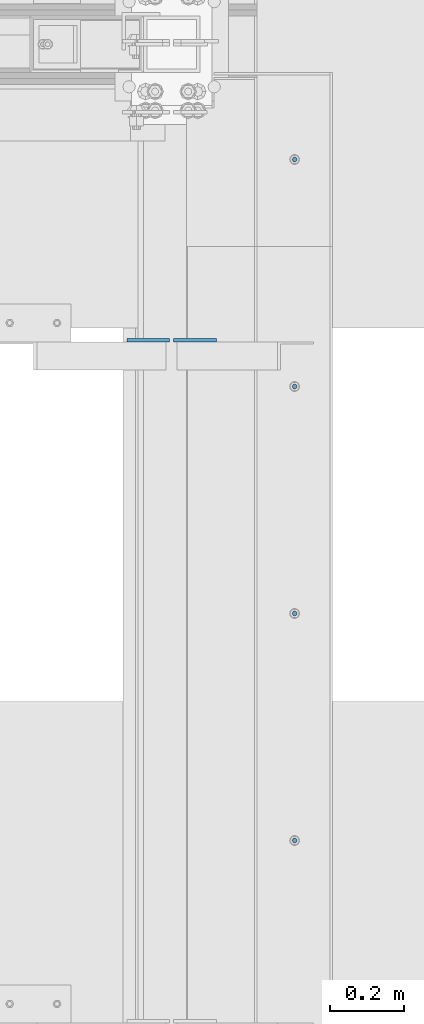
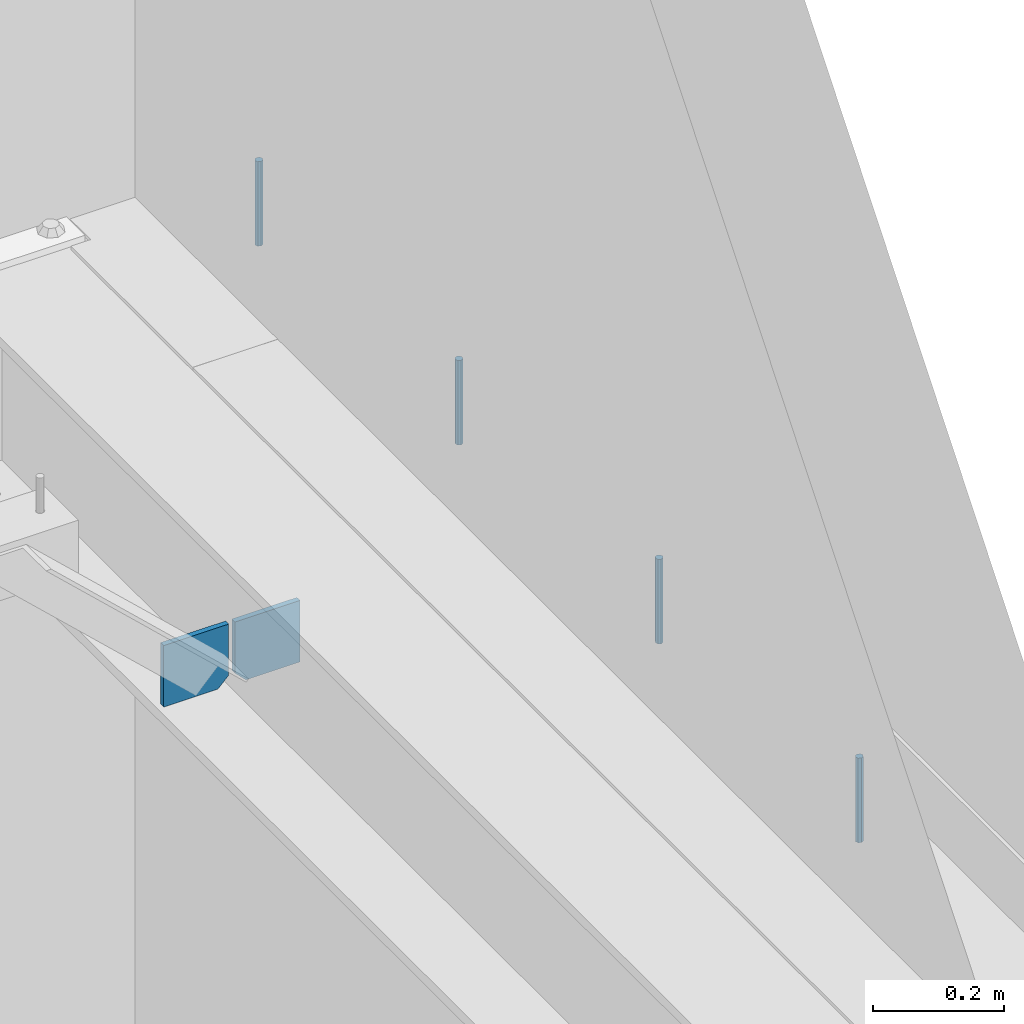
# One storey, part 569 of 1179: 6 columns, 1 element without a shape of its own.
"""IFC2X3 building model written with IfcOpenShell, lengths in millimetres."""

from ifc_helpers import new_model, si_unit, frame, origin_with_axes, place, context, subcontext, project, spatial, faceted_brep, material, type_object, element, aggregate, save


model = new_model("IFC2X3")

# Units and contexts
model_context = context("Model", 3, precision=1e-05, world=origin_with_axes())
body_context = subcontext(model_context, "Body", "Model", "MODEL_VIEW")
ifc_project = project(units=[si_unit("LENGTHUNIT", "METRE", prefix="MILLI"), si_unit("AREAUNIT", "SQUARE_METRE"), si_unit("VOLUMEUNIT", "CUBIC_METRE"), si_unit("MASSUNIT", "GRAM", prefix="KILO"), si_unit("TIMEUNIT", "SECOND"), si_unit("PLANEANGLEUNIT", "RADIAN"), si_unit("SOLIDANGLEUNIT", "STERADIAN"), si_unit("THERMODYNAMICTEMPERATUREUNIT", "DEGREE_CELSIUS"), si_unit("LUMINOUSINTENSITYUNIT", "LUMEN")], contexts=[model_context])

# Site, building, storey
site_placement = place(None, origin_with_axes())
site = spatial("IfcSite", under=ifc_project, at=site_placement, CompositionType="ELEMENT")
building_placement = place(site_placement, origin_with_axes())
building = spatial("IfcBuilding", under=site, at=building_placement, Name="Undefined", CompositionType="ELEMENT")
storey_placement = place(building_placement, origin_with_axes())
storey = spatial("IfcBuildingStorey", under=building, at=storey_placement, Name="Undefined", CompositionType="ELEMENT", Elevation=0.0)

# Assembly, columns
assembly_placement = place(storey_placement, origin_with_axes())
assembly = element("IfcElementAssembly", 1, at=assembly_placement, inside=storey, Name="BEAM", AssemblyPlace="NOTDEFINED", PredefinedType="RIGID_FRAME")
ifc_material_1 = material(Name="STEEL/A36")
column_type_1 = type_object("IfcColumnType", PredefinedType="NOTDEFINED")
column_1_placement = place(assembly_placement, frame((24245.09375, 37191.15625, 3702.05), z_axis=(1.0, 0.0, 0.0), x_axis=(0.0, 0.0, 1.0)))
column_1 = element("IfcColumn", 2, at=column_1_placement, type_object=column_type_1, material=ifc_material_1, Name="PLATE", context=body_context, shape_type="Brep", body=[
    faceted_brep([(19.0500000000002, 4.76250000000073, 57.1500000000015), (0.0, 4.76250000000073, 38.0999999999985), (0.0, -4.76250000000073, 38.0999999999985), (19.0500000000002, -4.76250000000073, 57.1500000000015), (114.300000000001, 4.76250000000073, 57.1500000000015), (114.300000000001, 4.76250000000073, -57.1500000000015), (0.0, 4.76250000000073, -57.1500000000015), (114.300000000001, -4.76250000000073, 57.1500000000015), (0.0, -4.76250000000073, -57.1500000000015), (114.300000000001, -4.76250000000073, -57.1500000000015)], [[[0, 1, 2, 3]], [[4, 5, 6, 1, 0]], [[7, 4, 0, 3]], [[8, 9, 7, 3, 2]], [[8, 6, 5, 9]], [[7, 9, 5, 4]], [[6, 8, 2, 1]]]),
])
column_2_placement = place(assembly_placement, frame((24370.50625, 37191.15625, 3702.05), z_axis=(-1.0, 0.0, 0.0), x_axis=(0.0, 0.0, 1.0)))
column_2 = element("IfcColumn", 3, at=column_2_placement, type_object=column_type_1, material=ifc_material_1, Name="PLATE", context=body_context, shape_type="Brep", body=[
    faceted_brep([(19.0500000000002, 4.76250000000073, 57.1500000000015), (0.0, 4.76250000000073, 38.0999999999985), (0.0, -4.76250000000073, 38.0999999999985), (19.0500000000002, -4.76250000000073, 57.1500000000015), (114.300000000001, 4.76250000000073, 57.1500000000015), (114.300000000001, 4.76250000000073, -57.1500000000015), (0.0, 4.76250000000073, -57.1500000000015), (114.300000000001, -4.76250000000073, 57.1500000000015), (0.0, -4.76250000000073, -57.1500000000015), (114.300000000001, -4.76250000000073, -57.1500000000015)], [[[0, 1, 2, 3]], [[4, 5, 6, 1, 0]], [[7, 4, 0, 3]], [[8, 9, 7, 3, 2]], [[8, 6, 5, 9]], [[7, 9, 5, 4]], [[6, 8, 2, 1]]]),
])
ifc_material_2 = material(Name="STEEL/A307")
column_type_2 = type_object("IfcColumnType", PredefinedType="NOTDEFINED")
column_3_placement = place(assembly_placement, frame((24638.0003519435, 37676.1375, 4108.45), z_axis=(0.0, 1.0, 0.0), x_axis=(0.0, 0.0, 1.0)))
column_3 = element("IfcColumn", 4, at=column_3_placement, type_object=column_type_2, material=ifc_material_2, Name="THREADED ROD", context=body_context, shape_type="Brep", body=[
    faceted_brep([(0.0, -6.34999999999854, 0.0), (0.0, -4.49012806053361, -4.49012806053452), (157.162499999999, -4.49012806053361, -4.49012806053361), (157.162499999999, -6.34999999999854, 0.0), (0.0, 0.0, -6.34999999999991), (157.162499999999, 0.0, -6.34999999999854), (0.0, 4.49012806053361, -4.49012806053452), (157.162499999999, 4.49012806053361, -4.49012806053361), (0.0, 6.34999999999854, 0.0), (157.162499999999, 6.34999999999854, 0.0), (0.0, 4.49012806053361, 4.49012806053452), (157.162499999999, 4.49012806053361, 4.49012806053361), (0.0, 0.0, 6.34999999999991), (157.162499999999, 0.0, 6.34999999999854), (0.0, -4.49012806053361, 4.49012806053452), (157.162499999999, -4.49012806053361, 4.49012806053361)], [[[0, 1, 2, 3]], [[1, 4, 5, 2]], [[4, 6, 7, 5]], [[6, 8, 9, 7]], [[8, 10, 11, 9]], [[10, 12, 13, 11]], [[12, 14, 15, 13]], [[14, 0, 3, 15]], [[5, 7, 9, 11, 13, 15, 3, 2]], [[14, 12, 10, 8, 6, 4, 1, 0]]]),
])
column_4_placement = place(assembly_placement, frame((24638.0003519435, 37066.5375, 4108.45), z_axis=(0.0, 1.0, 0.0), x_axis=(0.0, 0.0, 1.0)))
column_4 = element("IfcColumn", 5, at=column_4_placement, type_object=column_type_2, material=ifc_material_2, Name="THREADED ROD", context=body_context, shape_type="Brep", body=[
    faceted_brep([(0.0, -6.34999999999854, 0.0), (0.0, -4.49012806053361, -4.49012806053452), (157.162499999999, -4.49012806053361, -4.49012806053361), (157.162499999999, -6.34999999999854, 0.0), (0.0, 0.0, -6.34999999999991), (157.162499999999, 0.0, -6.34999999999854), (0.0, 4.49012806053361, -4.49012806053452), (157.162499999999, 4.49012806053361, -4.49012806053361), (0.0, 6.34999999999854, 0.0), (157.162499999999, 6.34999999999854, 0.0), (0.0, 4.49012806053361, 4.49012806053452), (157.162499999999, 4.49012806053361, 4.49012806053361), (0.0, 0.0, 6.34999999999991), (157.162499999999, 0.0, 6.34999999999854), (0.0, -4.49012806053361, 4.49012806053452), (157.162499999999, -4.49012806053361, 4.49012806053361)], [[[0, 1, 2, 3]], [[1, 4, 5, 2]], [[4, 6, 7, 5]], [[6, 8, 9, 7]], [[8, 10, 11, 9]], [[10, 12, 13, 11]], [[12, 14, 15, 13]], [[14, 0, 3, 15]], [[5, 7, 9, 11, 13, 15, 3, 2]], [[14, 12, 10, 8, 6, 4, 1, 0]]]),
])
column_5_placement = place(assembly_placement, frame((24638.0003519435, 36456.9375, 4108.45), z_axis=(0.0, 1.0, 0.0), x_axis=(0.0, 0.0, 1.0)))
column_5 = element("IfcColumn", 6, at=column_5_placement, type_object=column_type_2, material=ifc_material_2, Name="THREADED ROD", context=body_context, shape_type="Brep", body=[
    faceted_brep([(0.0, -6.34999999999854, 0.0), (0.0, -4.49012806053361, -4.49012806053452), (157.162499999999, -4.49012806053361, -4.49012806053361), (157.162499999999, -6.34999999999854, 0.0), (0.0, 0.0, -6.34999999999991), (157.162499999999, 0.0, -6.34999999999854), (0.0, 4.49012806053361, -4.49012806053452), (157.162499999999, 4.49012806053361, -4.49012806053361), (0.0, 6.34999999999854, 0.0), (157.162499999999, 6.34999999999854, 0.0), (0.0, 4.49012806053361, 4.49012806053452), (157.162499999999, 4.49012806053361, 4.49012806053361), (0.0, 0.0, 6.34999999999991), (157.162499999999, 0.0, 6.34999999999854), (0.0, -4.49012806053361, 4.49012806053452), (157.162499999999, -4.49012806053361, 4.49012806053361)], [[[0, 1, 2, 3]], [[1, 4, 5, 2]], [[4, 6, 7, 5]], [[6, 8, 9, 7]], [[8, 10, 11, 9]], [[10, 12, 13, 11]], [[12, 14, 15, 13]], [[14, 0, 3, 15]], [[5, 7, 9, 11, 13, 15, 3, 2]], [[14, 12, 10, 8, 6, 4, 1, 0]]]),
])
column_6_placement = place(assembly_placement, frame((24638.0003519435, 35847.3375, 4108.45), z_axis=(0.0, 1.0, 0.0), x_axis=(0.0, 0.0, 1.0)))
column_6 = element("IfcColumn", 7, at=column_6_placement, type_object=column_type_2, material=ifc_material_2, Name="THREADED ROD", context=body_context, shape_type="Brep", body=[
    faceted_brep([(0.0, -6.34999999999854, 0.0), (0.0, -4.49012806053361, -4.49012806053452), (157.162499999999, -4.49012806053361, -4.49012806053361), (157.162499999999, -6.34999999999854, 0.0), (0.0, 0.0, -6.34999999999991), (157.162499999999, 0.0, -6.34999999999854), (0.0, 4.49012806053361, -4.49012806053452), (157.162499999999, 4.49012806053361, -4.49012806053361), (0.0, 6.34999999999854, 0.0), (157.162499999999, 6.34999999999854, 0.0), (0.0, 4.49012806053361, 4.49012806053452), (157.162499999999, 4.49012806053361, 4.49012806053361), (0.0, 0.0, 6.34999999999991), (157.162499999999, 0.0, 6.34999999999854), (0.0, -4.49012806053361, 4.49012806053452), (157.162499999999, -4.49012806053361, 4.49012806053361)], [[[0, 1, 2, 3]], [[1, 4, 5, 2]], [[4, 6, 7, 5]], [[6, 8, 9, 7]], [[8, 10, 11, 9]], [[10, 12, 13, 11]], [[12, 14, 15, 13]], [[14, 0, 3, 15]], [[5, 7, 9, 11, 13, 15, 3, 2]], [[14, 12, 10, 8, 6, 4, 1, 0]]]),
])
aggregate(assembly, [column_3, column_4, column_5, column_6, column_1, column_2])

save(model, "model.ifc")
